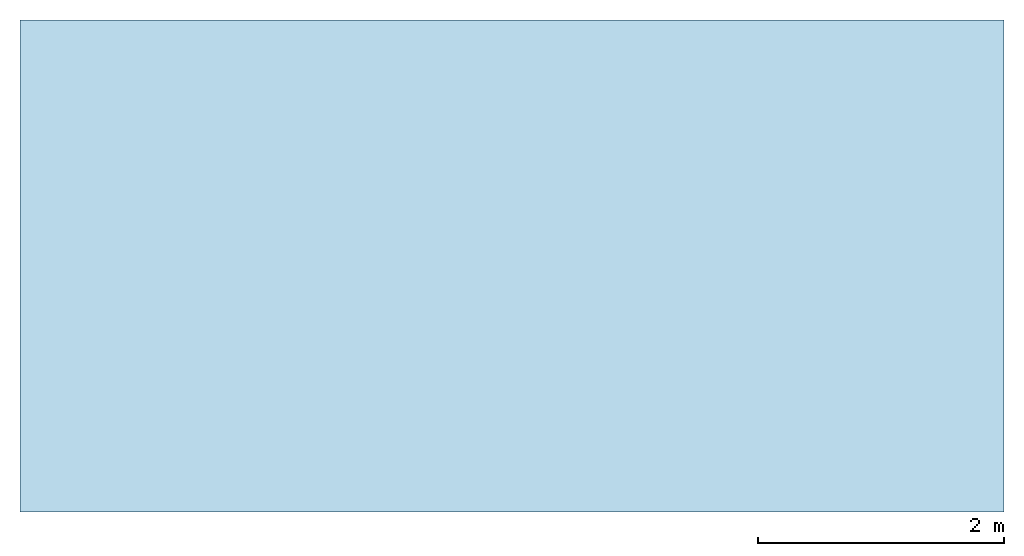
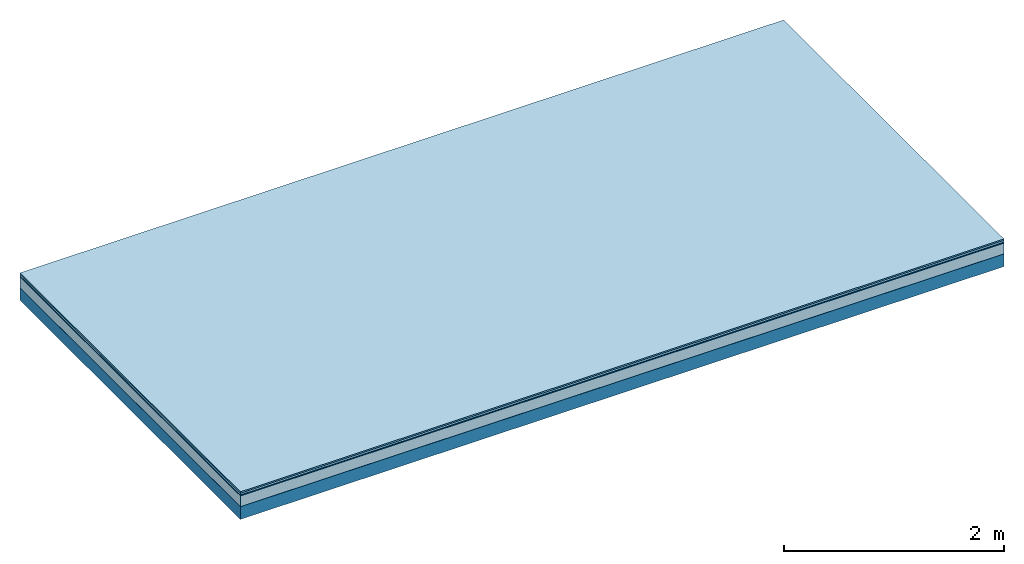
# One storey: 5 plates, 1 member, 1 element without a shape of its own.
"""IFC4 building model written with IfcOpenShell, lengths in metres."""

from ifc_helpers import new_model, si_unit, derived_unit, direction, frame, frame_2d, origin, origin_with_axes, place, context, project, spatial, rectangle, extrude, material, layer, layer_set, type_object, element, aggregate, save


model = new_model("IFC4")

# Units and contexts
plan_context = context("Plan", 3, precision=1e-05, world=origin(), true_north=direction((0.0, 1.0)))
model_context = context("Model", 3, precision=1e-05, world=origin(), true_north=direction((0.0, 1.0)))
ifc_project = project(units=[si_unit("LENGTHUNIT", "METRE"), derived_unit("SOUNDPRESSUREUNIT", [(si_unit("PRESSUREUNIT", "PASCAL", prefix="MICRO"), 0)]), si_unit("ENERGYUNIT", "JOULE", prefix="MEGA"), si_unit("MASSUNIT", "GRAM", prefix="KILO"), derived_unit("THERMALTRANSMITTANCEUNIT", [(si_unit("POWERUNIT", "WATT"), 1), (si_unit("AREAUNIT", "SQUARE_METRE"), -1), (si_unit("THERMODYNAMICTEMPERATUREUNIT", "KELVIN"), -1)]), derived_unit("AREADENSITYUNIT", [(si_unit("MASSUNIT", "GRAM", prefix="KILO"), 1), (si_unit("AREAUNIT", "SQUARE_METRE"), -1)]), derived_unit("USERDEFINED", [(si_unit("ENERGYUNIT", "JOULE", prefix="MEGA"), 1), (si_unit("AREAUNIT", "SQUARE_METRE"), -1)])], contexts=[plan_context, model_context])

# Site, building, storey
site = spatial("IfcSite", under=ifc_project)
building_placement = place(None, origin())
building = spatial("IfcBuilding", under=site, at=building_placement)
storey_placement = place(building_placement, origin())
storey = spatial("IfcBuildingStorey", under=building, at=storey_placement)

# Slab, member, plates
ifc_material_1 = material(Category="11.013")
ifc_layer_1 = layer(ifc_material_1, 0.015, Name="Flooring")
ifc_material_2 = material(Category="03.007")
ifc_layer_2 = layer(ifc_material_2, 0.02, Name="On-material")
ifc_material_3 = material(Name="Wood fiber generic product", Category="10.009")
ifc_layer_3 = layer(ifc_material_3, 0.01, Name="Impact sound insulation")
ifc_material_4 = material(Category="03.011")
ifc_layer_4 = layer(ifc_material_4, 0.12, Name="on Supporting structure")
ifc_material_5 = material(Name="protection", Category="09.007")
ifc_layer_5 = layer(ifc_material_5, 0.0005, Name="Sub-floor")
ifc_material_6 = material(Name="no composite action")
ifc_layer_6 = layer(ifc_material_6, 0.0, Name="Bond")
ifc_layer_7 = layer(None, 0.14, Name="Supporting structure")
ifc_layer_set = layer_set([ifc_layer_1, ifc_layer_2, ifc_layer_3, ifc_layer_4, ifc_layer_5, ifc_layer_6, ifc_layer_7])
slab_type = type_object("IfcSlabType", Name="A2052", PredefinedType="NOTDEFINED", material=ifc_layer_set)
slab_placement = place(None, frame((0.0, 0.0, 0.0), z_axis=(0.0, 0.0, -1.0), x_axis=(1.0, 0.0, 0.0)))
slab = element("IfcSlab", 1, at=slab_placement, inside=storey, type_object=slab_type, material=ifc_layer_set, Name="Slab #1")
ifc_material_7 = material(Name="Solid timber panel")
member_placement = place(slab_placement, origin())
member = element("IfcMember", 2, at=member_placement, material=ifc_material_7, Name="Supporting structure", context=plan_context, shape_type="SweptSolid", body=[
    extrude(rectangle(XDim=1.0, YDim=0.14, at=frame_2d((0.5, 0.07), x_axis=(1.0, 0.0))), frame((0.0, 4.0, 0.1655), z_axis=(0.0, -1.0, 0.0), x_axis=(1.0, 0.0, 0.0)), (0.0, 0.0, 1.0), 4.0),
    extrude(rectangle(XDim=1.0, YDim=0.14, at=frame_2d((0.5, 0.07), x_axis=(1.0, 0.0))), frame((1.0, 4.0, 0.1655), z_axis=(0.0, -1.0, 0.0), x_axis=(1.0, 0.0, 0.0)), (0.0, 0.0, 1.0), 4.0),
    extrude(rectangle(XDim=1.0, YDim=0.14, at=frame_2d((0.5, 0.07), x_axis=(1.0, 0.0))), frame((2.0, 4.0, 0.1655), z_axis=(0.0, -1.0, 0.0), x_axis=(1.0, 0.0, 0.0)), (0.0, 0.0, 1.0), 4.0),
    extrude(rectangle(XDim=1.0, YDim=0.14, at=frame_2d((0.5, 0.07), x_axis=(1.0, 0.0))), frame((3.0, 4.0, 0.1655), z_axis=(0.0, -1.0, 0.0), x_axis=(1.0, 0.0, 0.0)), (0.0, 0.0, 1.0), 4.0),
    extrude(rectangle(XDim=1.0, YDim=0.14, at=frame_2d((0.5, 0.07), x_axis=(1.0, 0.0))), frame((4.0, 4.0, 0.1655), z_axis=(0.0, -1.0, 0.0), x_axis=(1.0, 0.0, 0.0)), (0.0, 0.0, 1.0), 4.0),
    extrude(rectangle(XDim=1.0, YDim=0.14, at=frame_2d((0.5, 0.07), x_axis=(1.0, 0.0))), frame((5.0, 4.0, 0.1655), z_axis=(0.0, -1.0, 0.0), x_axis=(1.0, 0.0, 0.0)), (0.0, 0.0, 1.0), 4.0),
    extrude(rectangle(XDim=1.0, YDim=0.14, at=frame_2d((0.5, 0.07), x_axis=(1.0, 0.0))), frame((6.0, 4.0, 0.1655), z_axis=(0.0, -1.0, 0.0), x_axis=(1.0, 0.0, 0.0)), (0.0, 0.0, 1.0), 4.0),
    extrude(rectangle(XDim=1.0, YDim=0.14, at=frame_2d((0.5, 0.07), x_axis=(1.0, 0.0))), frame((7.0, 4.0, 0.1655), z_axis=(0.0, -1.0, 0.0), x_axis=(1.0, 0.0, 0.0)), (0.0, 0.0, 1.0), 4.0),
])
plate_1_placement = place(slab_placement, origin())
plate_1 = element("IfcPlate", 3, at=plate_1_placement, material=ifc_material_1, Name="Flooring", context=plan_context, shape_type="SweptSolid", body=[
    extrude(rectangle(XDim=8.0, YDim=4.0, at=frame_2d((4.0, 2.0), x_axis=(1.0, 0.0))), origin_with_axes(), (0.0, 0.0, 1.0), 0.015),
])
plate_2_placement = place(slab_placement, origin())
plate_2 = element("IfcPlate", 4, at=plate_2_placement, material=ifc_material_2, Name="On-material", context=plan_context, shape_type="SweptSolid", body=[
    extrude(rectangle(XDim=8.0, YDim=4.0, at=frame_2d((4.0, 2.0), x_axis=(1.0, 0.0))), frame((0.0, 0.0, 0.015), z_axis=(0.0, 0.0, 1.0), x_axis=(1.0, 0.0, 0.0)), (0.0, 0.0, 1.0), 0.02),
])
plate_3_placement = place(slab_placement, origin())
plate_3 = element("IfcPlate", 5, at=plate_3_placement, material=ifc_material_3, Name="Impact sound insulation", context=plan_context, shape_type="SweptSolid", body=[
    extrude(rectangle(XDim=8.0, YDim=4.0, at=frame_2d((4.0, 2.0), x_axis=(1.0, 0.0))), frame((0.0, 0.0, 0.035), z_axis=(0.0, 0.0, 1.0), x_axis=(1.0, 0.0, 0.0)), (0.0, 0.0, 1.0), 0.01),
])
plate_4_placement = place(slab_placement, origin())
plate_4 = element("IfcPlate", 6, at=plate_4_placement, material=ifc_material_4, Name="on Supporting structure", context=plan_context, shape_type="SweptSolid", body=[
    extrude(rectangle(XDim=8.0, YDim=4.0, at=frame_2d((4.0, 2.0), x_axis=(1.0, 0.0))), frame((0.0, 0.0, 0.045), z_axis=(0.0, 0.0, 1.0), x_axis=(1.0, 0.0, 0.0)), (0.0, 0.0, 1.0), 0.12),
])
plate_5_placement = place(slab_placement, origin())
plate_5 = element("IfcPlate", 7, at=plate_5_placement, material=ifc_material_5, Name="Sub-floor", context=plan_context, shape_type="SweptSolid", body=[
    extrude(rectangle(XDim=8.0, YDim=4.0, at=frame_2d((4.0, 2.0), x_axis=(1.0, 0.0))), frame((0.0, 0.0, 0.165), z_axis=(0.0, 0.0, 1.0), x_axis=(1.0, 0.0, 0.0)), (0.0, 0.0, 1.0), 0.0005),
])
aggregate(slab, [plate_1, plate_2, plate_3, plate_4, plate_5, member])

save(model, "model.ifc")
